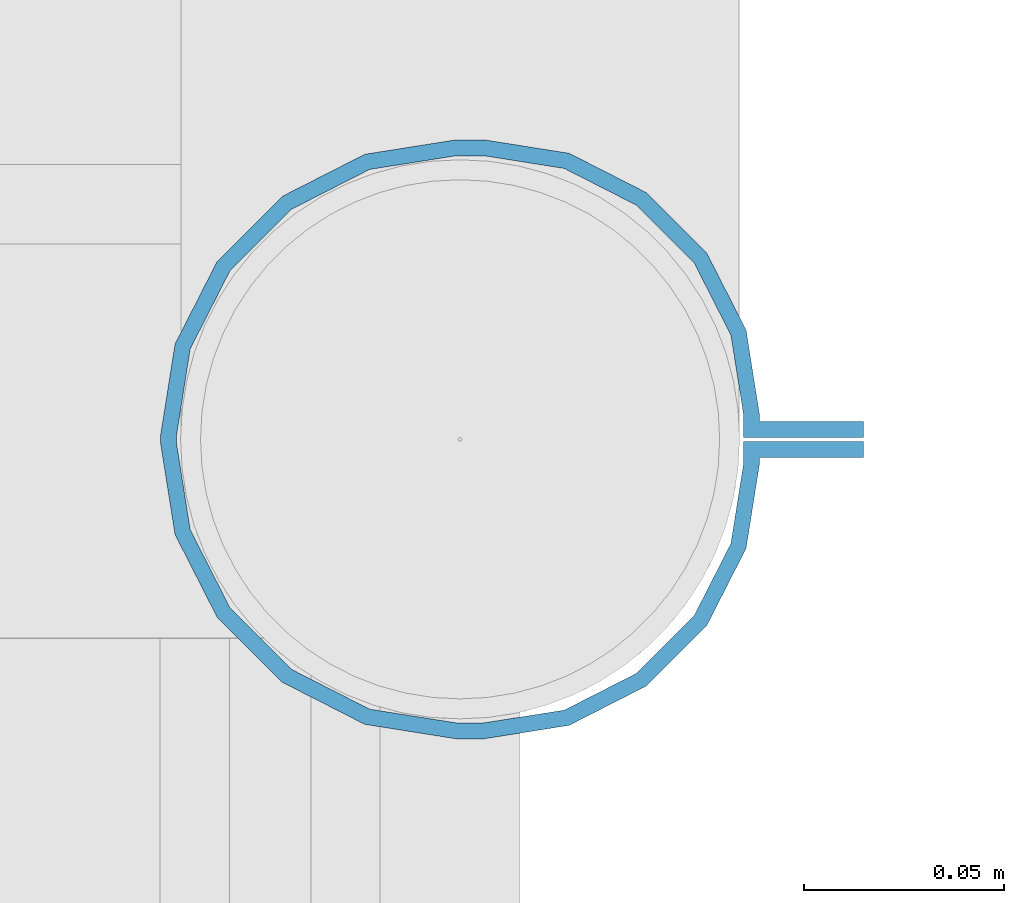
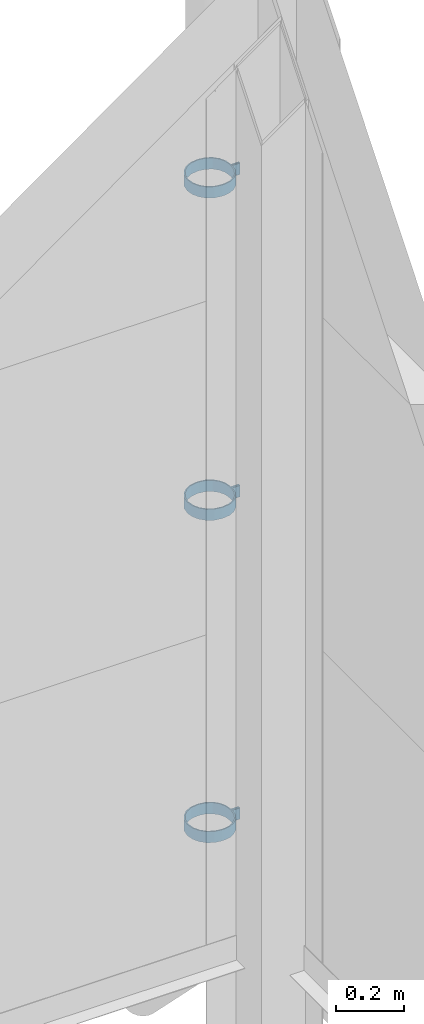
# One storey, part 324 of 709: 3 beams, 3 elements without a shape of their own.
"""IFC4 building model written with IfcOpenShell, lengths in millimetres."""

from ifc_helpers import new_model, si_unit, direction, frame, origin_with_axes, place, context, subcontext, project, spatial, polygons, material, element, aggregate, save


model = new_model("IFC4")

# Units and contexts
model_context = context("Model", 3, precision=0.2, world=origin_with_axes(), true_north=direction((0.0, 1.0)))
body_context = subcontext(model_context, "Body", "Model", "MODEL_VIEW")
ifc_project = project(units=[si_unit("LENGTHUNIT", "METRE", prefix="MILLI"), si_unit("AREAUNIT", "SQUARE_METRE"), si_unit("VOLUMEUNIT", "CUBIC_METRE"), si_unit("MASSUNIT", "GRAM", prefix="KILO"), si_unit("TIMEUNIT", "SECOND"), si_unit("PLANEANGLEUNIT", "RADIAN"), si_unit("SOLIDANGLEUNIT", "STERADIAN"), si_unit("THERMODYNAMICTEMPERATUREUNIT", "DEGREE_CELSIUS"), si_unit("LUMINOUSINTENSITYUNIT", "LUMEN")], contexts=[model_context])

# Site, building, storey
site_placement = place(None, origin_with_axes())
site = spatial("IfcSite", under=ifc_project, at=site_placement, CompositionType="ELEMENT")
building_placement = place(site_placement, origin_with_axes())
building = spatial("IfcBuilding", under=site, at=building_placement, Name="Undefined", CompositionType="ELEMENT")
storey_placement = place(building_placement, origin_with_axes())
storey = spatial("IfcBuildingStorey", under=building, at=storey_placement, Name="Undefined", CompositionType="ELEMENT", Elevation=0.0)

# Assembly, beam
assembly_1_placement = place(storey_placement, frame((50101.0, 22422.5, 2776.92297), z_axis=(0.0, 1.0, 0.0), x_axis=(-1.0, 0.0, 0.0)))
assembly_1 = element("IfcElementAssembly", 1, at=assembly_1_placement, inside=storey)
ifc_material = material(Name="Steel_Undefined", Category="STEEL")
beam_1_placement = place(assembly_1_placement, origin_with_axes())
beam_1 = element("IfcBeam", 2, at=beam_1_placement, material=ifc_material, ObjectType="616", context=body_context, shape_type="Tessellation", body=[
    polygons([(0.0, -20.0, 2.0), (0.0, 20.0, 2.0), (0.0, 20.0, -2.0), (0.0, -20.0, -2.0), (30.0, 20.0, -2.0), (30.0, -20.0, -2.0), (26.0, -20.0, 2.0), (26.0, 20.0, 2.0), (30.0, 20.0, 3.5), (30.0, -20.0, 3.5), (26.0, -20.0, 3.5), (26.0, 20.0, 3.5), (33.18133, 20.0, 23.5861), (33.18133, -20.0, 23.5861), (29.3771, -20.0, 24.82217), (29.3771, 20.0, 24.82217), (39.17783, -20.0, 44.05718), (39.17783, 20.0, 44.05718), (42.4139, 20.0, 41.70604), (42.4139, -20.0, 41.70604), (54.44282, -20.0, 59.32217), (54.44282, 20.0, 59.32217), (56.79396, 20.0, 56.0861), (56.79396, -20.0, 56.0861), (73.67783, -20.0, 69.1229), (73.67783, 20.0, 69.1229), (74.9139, 20.0, 65.31867), (74.9139, -20.0, 65.31867), (95.0, -20.0, 72.5), (95.0, 20.0, 72.5), (95.0, 20.0, 68.5), (95.0, -20.0, 68.5), (102.0, 20.0, 68.5), (102.0, -20.0, 68.5), (102.0, -20.0, 72.5), (102.0, 20.0, 72.5), (123.63119, 20.0, 65.07396), (123.63119, -20.0, 65.07396), (124.86726, -20.0, 68.87818), (124.86726, 20.0, 68.87818), (145.49611, -20.0, 58.36726), (145.49611, 20.0, 58.36726), (143.14497, 20.0, 55.13119), (143.14497, -20.0, 55.13119), (161.86726, -20.0, 41.99611), (161.86726, 20.0, 41.99611), (158.63119, 20.0, 39.64497), (158.63119, -20.0, 39.64497), (172.37818, -20.0, 21.36726), (172.37818, 20.0, 21.36726), (168.57396, 20.0, 20.13119), (168.57396, -20.0, 20.13119), (176.0, -20.0, -1.5), (176.0, 20.0, -1.5), (172.0, 20.0, -1.5), (172.0, -20.0, -1.5), (172.0, 20.0, -3.5), (172.0, -20.0, -3.5), (176.0, -20.0, -3.5), (176.0, 20.0, -3.5), (168.57396, 20.0, -25.13119), (168.57396, -20.0, -25.13119), (172.37818, -20.0, -26.36726), (172.37818, 20.0, -26.36726), (161.86726, -20.0, -46.99611), (161.86726, 20.0, -46.99611), (158.63119, 20.0, -44.64497), (158.63119, -20.0, -44.64497), (145.49611, -20.0, -63.36726), (145.49611, 20.0, -63.36726), (143.14497, 20.0, -60.13119), (143.14497, -20.0, -60.13119), (124.86726, -20.0, -73.87818), (124.86726, 20.0, -73.87818), (123.63119, 20.0, -70.07396), (123.63119, -20.0, -70.07396), (102.0, -20.0, -77.5), (102.0, 20.0, -77.5), (102.0, 20.0, -73.5), (102.0, -20.0, -73.5), (95.0, 20.0, -73.5), (95.0, -20.0, -73.5), (95.0, -20.0, -77.5), (95.0, 20.0, -77.5), (74.9139, 20.0, -70.31867), (74.9139, -20.0, -70.31867), (73.67783, -20.0, -74.1229), (73.67783, 20.0, -74.1229), (54.44282, -20.0, -64.32217), (54.44282, 20.0, -64.32217), (56.79396, 20.0, -61.0861), (56.79396, -20.0, -61.0861), (39.17783, -20.0, -49.05718), (39.17783, 20.0, -49.05718), (42.4139, 20.0, -46.70604), (42.4139, -20.0, -46.70604), (29.3771, -20.0, -29.82217), (29.3771, 20.0, -29.82217), (33.18133, 20.0, -28.5861), (33.18133, -20.0, -28.5861), (26.0, -20.0, -8.5), (26.0, 20.0, -8.5), (30.0, 20.0, -8.5), (30.0, -20.0, -8.5), (30.0, 20.0, -3.0), (30.0, -20.0, -3.0), (26.0, -20.0, -7.0), (26.0, 20.0, -7.0), (0.0, 20.0, -3.0), (0.0, -20.0, -3.0), (0.0, 20.0, -7.0), (0.0, -20.0, -7.0)], [[[1, 2, 3, 4]], [[4, 3, 5, 6]], [[2, 1, 7, 8]], [[6, 5, 9, 10]], [[8, 7, 11, 12]], [[10, 9, 13, 14]], [[12, 11, 15, 16]], [[15, 17, 18, 16]], [[13, 19, 20, 14]], [[17, 21, 22, 18]], [[19, 23, 24, 20]], [[21, 25, 26, 22]], [[23, 27, 28, 24]], [[25, 29, 30, 26]], [[27, 31, 32, 28]], [[32, 31, 33, 34]], [[30, 29, 35, 36]], [[34, 33, 37, 38]], [[36, 35, 39, 40]], [[39, 41, 42, 40]], [[37, 43, 44, 38]], [[41, 45, 46, 42]], [[43, 47, 48, 44]], [[45, 49, 50, 46]], [[47, 51, 52, 48]], [[49, 53, 54, 50]], [[51, 55, 56, 52]], [[56, 55, 57, 58]], [[54, 53, 59, 60]], [[58, 57, 61, 62]], [[60, 59, 63, 64]], [[63, 65, 66, 64]], [[61, 67, 68, 62]], [[65, 69, 70, 66]], [[67, 71, 72, 68]], [[69, 73, 74, 70]], [[71, 75, 76, 72]], [[73, 77, 78, 74]], [[75, 79, 80, 76]], [[80, 79, 81, 82]], [[78, 77, 83, 84]], [[82, 81, 85, 86]], [[84, 83, 87, 88]], [[87, 89, 90, 88]], [[85, 91, 92, 86]], [[89, 93, 94, 90]], [[91, 95, 96, 92]], [[93, 97, 98, 94]], [[95, 99, 100, 96]], [[97, 101, 102, 98]], [[99, 103, 104, 100]], [[104, 103, 105, 106]], [[102, 101, 107, 108]], [[106, 105, 109, 110]], [[105, 103, 99, 95, 91, 85, 81, 79, 75, 71, 67, 61, 57, 55, 51, 47, 43, 37, 33, 31, 27, 23, 19, 13, 9, 5, 3, 2, 8, 12, 16, 18, 22, 26, 30, 36, 40, 42, 46, 50, 54, 60, 64, 66, 70, 74, 78, 84, 88, 90, 94, 98, 102, 108, 111, 109]], [[108, 107, 112, 111]], [[107, 101, 97, 93, 89, 87, 83, 77, 73, 69, 65, 63, 59, 53, 49, 45, 41, 39, 35, 29, 25, 21, 17, 15, 11, 7, 1, 4, 6, 10, 14, 20, 24, 28, 32, 34, 38, 44, 48, 52, 56, 58, 62, 68, 72, 76, 80, 82, 86, 92, 96, 100, 104, 106, 110, 112]], [[111, 112, 110, 109]]], closed=True),
])
aggregate(assembly_1, [beam_1])

assembly_2_placement = place(storey_placement, frame((50101.0, 22422.5, 1626.92297), z_axis=(0.0, 1.0, 0.0), x_axis=(-1.0, 0.0, 0.0)))
assembly_2 = element("IfcElementAssembly", 3, at=assembly_2_placement, inside=storey)
beam_2_placement = place(assembly_2_placement, origin_with_axes())
beam_2 = element("IfcBeam", 4, at=beam_2_placement, material=ifc_material, ObjectType="616", context=body_context, shape_type="Tessellation", body=[
    polygons([(0.0, -20.0, 2.0), (0.0, 20.0, 2.0), (0.0, 20.0, -2.0), (0.0, -20.0, -2.0), (30.0, 20.0, -2.0), (30.0, -20.0, -2.0), (26.0, -20.0, 2.0), (26.0, 20.0, 2.0), (30.0, 20.0, 3.5), (30.0, -20.0, 3.5), (26.0, -20.0, 3.5), (26.0, 20.0, 3.5), (33.18133, 20.0, 23.5861), (33.18133, -20.0, 23.5861), (29.3771, -20.0, 24.82217), (29.3771, 20.0, 24.82217), (39.17783, -20.0, 44.05718), (39.17783, 20.0, 44.05718), (42.4139, 20.0, 41.70604), (42.4139, -20.0, 41.70604), (54.44282, -20.0, 59.32217), (54.44282, 20.0, 59.32217), (56.79396, 20.0, 56.0861), (56.79396, -20.0, 56.0861), (73.67783, -20.0, 69.1229), (73.67783, 20.0, 69.1229), (74.9139, 20.0, 65.31867), (74.9139, -20.0, 65.31867), (95.0, -20.0, 72.5), (95.0, 20.0, 72.5), (95.0, 20.0, 68.5), (95.0, -20.0, 68.5), (102.0, 20.0, 68.5), (102.0, -20.0, 68.5), (102.0, -20.0, 72.5), (102.0, 20.0, 72.5), (123.63119, 20.0, 65.07396), (123.63119, -20.0, 65.07396), (124.86726, -20.0, 68.87818), (124.86726, 20.0, 68.87818), (145.49611, -20.0, 58.36726), (145.49611, 20.0, 58.36726), (143.14497, 20.0, 55.13119), (143.14497, -20.0, 55.13119), (161.86726, -20.0, 41.99611), (161.86726, 20.0, 41.99611), (158.63119, 20.0, 39.64497), (158.63119, -20.0, 39.64497), (172.37818, -20.0, 21.36726), (172.37818, 20.0, 21.36726), (168.57396, 20.0, 20.13119), (168.57396, -20.0, 20.13119), (176.0, -20.0, -1.5), (176.0, 20.0, -1.5), (172.0, 20.0, -1.5), (172.0, -20.0, -1.5), (172.0, 20.0, -3.5), (172.0, -20.0, -3.5), (176.0, -20.0, -3.5), (176.0, 20.0, -3.5), (168.57396, 20.0, -25.13119), (168.57396, -20.0, -25.13119), (172.37818, -20.0, -26.36726), (172.37818, 20.0, -26.36726), (161.86726, -20.0, -46.99611), (161.86726, 20.0, -46.99611), (158.63119, 20.0, -44.64497), (158.63119, -20.0, -44.64497), (145.49611, -20.0, -63.36726), (145.49611, 20.0, -63.36726), (143.14497, 20.0, -60.13119), (143.14497, -20.0, -60.13119), (124.86726, -20.0, -73.87818), (124.86726, 20.0, -73.87818), (123.63119, 20.0, -70.07396), (123.63119, -20.0, -70.07396), (102.0, -20.0, -77.5), (102.0, 20.0, -77.5), (102.0, 20.0, -73.5), (102.0, -20.0, -73.5), (95.0, 20.0, -73.5), (95.0, -20.0, -73.5), (95.0, -20.0, -77.5), (95.0, 20.0, -77.5), (74.9139, 20.0, -70.31867), (74.9139, -20.0, -70.31867), (73.67783, -20.0, -74.1229), (73.67783, 20.0, -74.1229), (54.44282, -20.0, -64.32217), (54.44282, 20.0, -64.32217), (56.79396, 20.0, -61.0861), (56.79396, -20.0, -61.0861), (39.17783, -20.0, -49.05718), (39.17783, 20.0, -49.05718), (42.4139, 20.0, -46.70604), (42.4139, -20.0, -46.70604), (29.3771, -20.0, -29.82217), (29.3771, 20.0, -29.82217), (33.18133, 20.0, -28.5861), (33.18133, -20.0, -28.5861), (26.0, -20.0, -8.5), (26.0, 20.0, -8.5), (30.0, 20.0, -8.5), (30.0, -20.0, -8.5), (30.0, 20.0, -3.0), (30.0, -20.0, -3.0), (26.0, -20.0, -7.0), (26.0, 20.0, -7.0), (0.0, 20.0, -3.0), (0.0, -20.0, -3.0), (0.0, 20.0, -7.0), (0.0, -20.0, -7.0)], [[[1, 2, 3, 4]], [[4, 3, 5, 6]], [[2, 1, 7, 8]], [[6, 5, 9, 10]], [[8, 7, 11, 12]], [[10, 9, 13, 14]], [[12, 11, 15, 16]], [[15, 17, 18, 16]], [[13, 19, 20, 14]], [[17, 21, 22, 18]], [[19, 23, 24, 20]], [[21, 25, 26, 22]], [[23, 27, 28, 24]], [[25, 29, 30, 26]], [[27, 31, 32, 28]], [[32, 31, 33, 34]], [[30, 29, 35, 36]], [[34, 33, 37, 38]], [[36, 35, 39, 40]], [[39, 41, 42, 40]], [[37, 43, 44, 38]], [[41, 45, 46, 42]], [[43, 47, 48, 44]], [[45, 49, 50, 46]], [[47, 51, 52, 48]], [[49, 53, 54, 50]], [[51, 55, 56, 52]], [[56, 55, 57, 58]], [[54, 53, 59, 60]], [[58, 57, 61, 62]], [[60, 59, 63, 64]], [[63, 65, 66, 64]], [[61, 67, 68, 62]], [[65, 69, 70, 66]], [[67, 71, 72, 68]], [[69, 73, 74, 70]], [[71, 75, 76, 72]], [[73, 77, 78, 74]], [[75, 79, 80, 76]], [[80, 79, 81, 82]], [[78, 77, 83, 84]], [[82, 81, 85, 86]], [[84, 83, 87, 88]], [[87, 89, 90, 88]], [[85, 91, 92, 86]], [[89, 93, 94, 90]], [[91, 95, 96, 92]], [[93, 97, 98, 94]], [[95, 99, 100, 96]], [[97, 101, 102, 98]], [[99, 103, 104, 100]], [[104, 103, 105, 106]], [[102, 101, 107, 108]], [[106, 105, 109, 110]], [[105, 103, 99, 95, 91, 85, 81, 79, 75, 71, 67, 61, 57, 55, 51, 47, 43, 37, 33, 31, 27, 23, 19, 13, 9, 5, 3, 2, 8, 12, 16, 18, 22, 26, 30, 36, 40, 42, 46, 50, 54, 60, 64, 66, 70, 74, 78, 84, 88, 90, 94, 98, 102, 108, 111, 109]], [[108, 107, 112, 111]], [[107, 101, 97, 93, 89, 87, 83, 77, 73, 69, 65, 63, 59, 53, 49, 45, 41, 39, 35, 29, 25, 21, 17, 15, 11, 7, 1, 4, 6, 10, 14, 20, 24, 28, 32, 34, 38, 44, 48, 52, 56, 58, 62, 68, 72, 76, 80, 82, 86, 92, 96, 100, 104, 106, 110, 112]], [[111, 112, 110, 109]]], closed=True),
])
aggregate(assembly_2, [beam_2])

assembly_3_placement = place(storey_placement, frame((50101.0, 22422.5, 476.92297), z_axis=(0.0, 1.0, 0.0), x_axis=(-1.0, 0.0, 0.0)))
assembly_3 = element("IfcElementAssembly", 5, at=assembly_3_placement, inside=storey)
beam_3_placement = place(assembly_3_placement, origin_with_axes())
beam_3 = element("IfcBeam", 6, at=beam_3_placement, material=ifc_material, ObjectType="616", context=body_context, shape_type="Tessellation", body=[
    polygons([(0.0, -20.0, 2.0), (0.0, 20.0, 2.0), (0.0, 20.0, -2.0), (0.0, -20.0, -2.0), (30.0, 20.0, -2.0), (30.0, -20.0, -2.0), (26.0, -20.0, 2.0), (26.0, 20.0, 2.0), (30.0, 20.0, 3.5), (30.0, -20.0, 3.5), (26.0, -20.0, 3.5), (26.0, 20.0, 3.5), (33.18133, 20.0, 23.5861), (33.18133, -20.0, 23.5861), (29.3771, -20.0, 24.82217), (29.3771, 20.0, 24.82217), (39.17783, -20.0, 44.05718), (39.17783, 20.0, 44.05718), (42.4139, 20.0, 41.70604), (42.4139, -20.0, 41.70604), (54.44282, -20.0, 59.32217), (54.44282, 20.0, 59.32217), (56.79396, 20.0, 56.0861), (56.79396, -20.0, 56.0861), (73.67783, -20.0, 69.1229), (73.67783, 20.0, 69.1229), (74.9139, 20.0, 65.31867), (74.9139, -20.0, 65.31867), (95.0, -20.0, 72.5), (95.0, 20.0, 72.5), (95.0, 20.0, 68.5), (95.0, -20.0, 68.5), (102.0, 20.0, 68.5), (102.0, -20.0, 68.5), (102.0, -20.0, 72.5), (102.0, 20.0, 72.5), (123.63119, 20.0, 65.07396), (123.63119, -20.0, 65.07396), (124.86726, -20.0, 68.87818), (124.86726, 20.0, 68.87818), (145.49611, -20.0, 58.36726), (145.49611, 20.0, 58.36726), (143.14497, 20.0, 55.13119), (143.14497, -20.0, 55.13119), (161.86726, -20.0, 41.99611), (161.86726, 20.0, 41.99611), (158.63119, 20.0, 39.64497), (158.63119, -20.0, 39.64497), (172.37818, -20.0, 21.36726), (172.37818, 20.0, 21.36726), (168.57396, 20.0, 20.13119), (168.57396, -20.0, 20.13119), (176.0, -20.0, -1.5), (176.0, 20.0, -1.5), (172.0, 20.0, -1.5), (172.0, -20.0, -1.5), (172.0, 20.0, -3.5), (172.0, -20.0, -3.5), (176.0, -20.0, -3.5), (176.0, 20.0, -3.5), (168.57396, 20.0, -25.13119), (168.57396, -20.0, -25.13119), (172.37818, -20.0, -26.36726), (172.37818, 20.0, -26.36726), (161.86726, -20.0, -46.99611), (161.86726, 20.0, -46.99611), (158.63119, 20.0, -44.64497), (158.63119, -20.0, -44.64497), (145.49611, -20.0, -63.36726), (145.49611, 20.0, -63.36726), (143.14497, 20.0, -60.13119), (143.14497, -20.0, -60.13119), (124.86726, -20.0, -73.87818), (124.86726, 20.0, -73.87818), (123.63119, 20.0, -70.07396), (123.63119, -20.0, -70.07396), (102.0, -20.0, -77.5), (102.0, 20.0, -77.5), (102.0, 20.0, -73.5), (102.0, -20.0, -73.5), (95.0, 20.0, -73.5), (95.0, -20.0, -73.5), (95.0, -20.0, -77.5), (95.0, 20.0, -77.5), (74.9139, 20.0, -70.31867), (74.9139, -20.0, -70.31867), (73.67783, -20.0, -74.1229), (73.67783, 20.0, -74.1229), (54.44282, -20.0, -64.32217), (54.44282, 20.0, -64.32217), (56.79396, 20.0, -61.0861), (56.79396, -20.0, -61.0861), (39.17783, -20.0, -49.05718), (39.17783, 20.0, -49.05718), (42.4139, 20.0, -46.70604), (42.4139, -20.0, -46.70604), (29.3771, -20.0, -29.82217), (29.3771, 20.0, -29.82217), (33.18133, 20.0, -28.5861), (33.18133, -20.0, -28.5861), (26.0, -20.0, -8.5), (26.0, 20.0, -8.5), (30.0, 20.0, -8.5), (30.0, -20.0, -8.5), (30.0, 20.0, -3.0), (30.0, -20.0, -3.0), (26.0, -20.0, -7.0), (26.0, 20.0, -7.0), (0.0, 20.0, -3.0), (0.0, -20.0, -3.0), (0.0, 20.0, -7.0), (0.0, -20.0, -7.0)], [[[1, 2, 3, 4]], [[4, 3, 5, 6]], [[2, 1, 7, 8]], [[6, 5, 9, 10]], [[8, 7, 11, 12]], [[10, 9, 13, 14]], [[12, 11, 15, 16]], [[15, 17, 18, 16]], [[13, 19, 20, 14]], [[17, 21, 22, 18]], [[19, 23, 24, 20]], [[21, 25, 26, 22]], [[23, 27, 28, 24]], [[25, 29, 30, 26]], [[27, 31, 32, 28]], [[32, 31, 33, 34]], [[30, 29, 35, 36]], [[34, 33, 37, 38]], [[36, 35, 39, 40]], [[39, 41, 42, 40]], [[37, 43, 44, 38]], [[41, 45, 46, 42]], [[43, 47, 48, 44]], [[45, 49, 50, 46]], [[47, 51, 52, 48]], [[49, 53, 54, 50]], [[51, 55, 56, 52]], [[56, 55, 57, 58]], [[54, 53, 59, 60]], [[58, 57, 61, 62]], [[60, 59, 63, 64]], [[63, 65, 66, 64]], [[61, 67, 68, 62]], [[65, 69, 70, 66]], [[67, 71, 72, 68]], [[69, 73, 74, 70]], [[71, 75, 76, 72]], [[73, 77, 78, 74]], [[75, 79, 80, 76]], [[80, 79, 81, 82]], [[78, 77, 83, 84]], [[82, 81, 85, 86]], [[84, 83, 87, 88]], [[87, 89, 90, 88]], [[85, 91, 92, 86]], [[89, 93, 94, 90]], [[91, 95, 96, 92]], [[93, 97, 98, 94]], [[95, 99, 100, 96]], [[97, 101, 102, 98]], [[99, 103, 104, 100]], [[104, 103, 105, 106]], [[102, 101, 107, 108]], [[106, 105, 109, 110]], [[105, 103, 99, 95, 91, 85, 81, 79, 75, 71, 67, 61, 57, 55, 51, 47, 43, 37, 33, 31, 27, 23, 19, 13, 9, 5, 3, 2, 8, 12, 16, 18, 22, 26, 30, 36, 40, 42, 46, 50, 54, 60, 64, 66, 70, 74, 78, 84, 88, 90, 94, 98, 102, 108, 111, 109]], [[108, 107, 112, 111]], [[107, 101, 97, 93, 89, 87, 83, 77, 73, 69, 65, 63, 59, 53, 49, 45, 41, 39, 35, 29, 25, 21, 17, 15, 11, 7, 1, 4, 6, 10, 14, 20, 24, 28, 32, 34, 38, 44, 48, 52, 56, 58, 62, 68, 72, 76, 80, 82, 86, 92, 96, 100, 104, 106, 110, 112]], [[111, 112, 110, 109]]], closed=True),
])
aggregate(assembly_3, [beam_3])

save(model, "model.ifc")
